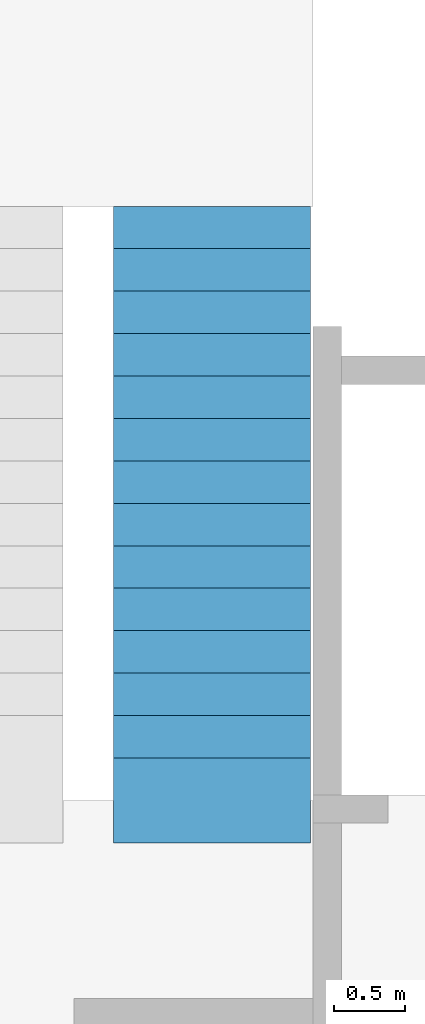
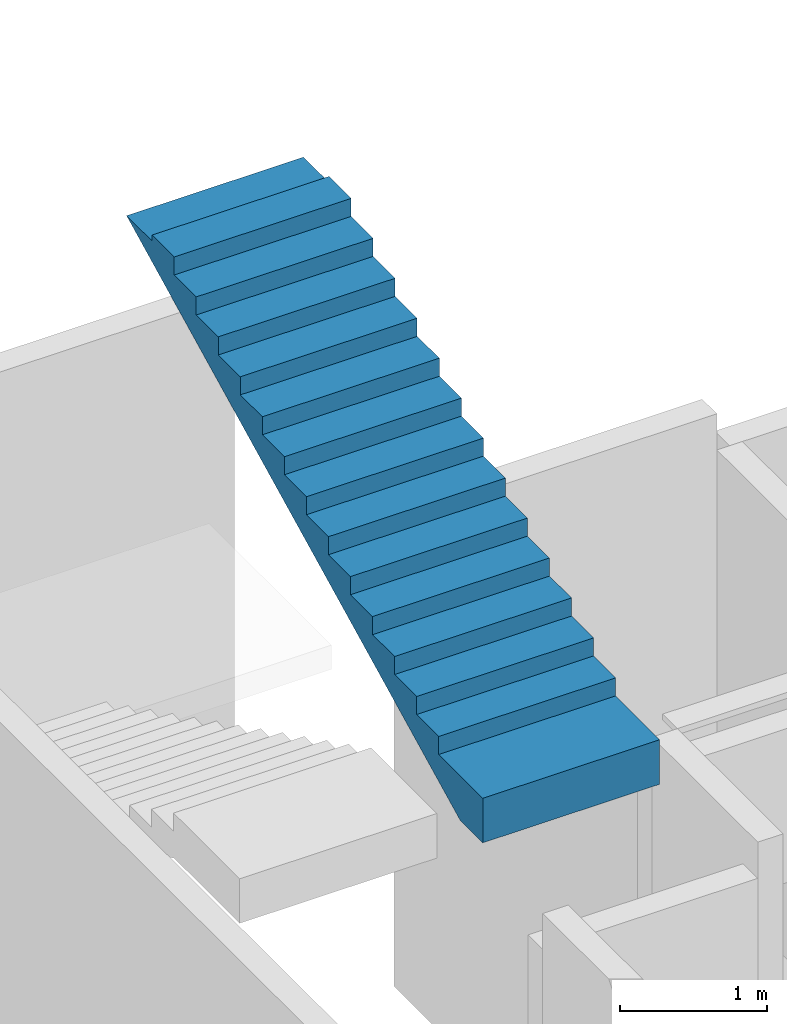
# One storey, part 22 of 92: 1 stair.
"""IFC4 building model written with IfcOpenShell, lengths in millimetres."""

from ifc_helpers import new_model, entity, si_unit, converted_unit, derived_unit, direction, frame, origin, place, context, subcontext, project, spatial, indexed_curve, outline, extrude, material, type_object, element, save


model = new_model("IFC4")

# Units and contexts
model_context = context("Model", 3, precision=0.01, world=origin(), true_north=direction((6.12303176911189e-17, 1.0)))
plan_context = context("Plan", 3, precision=0.01, world=origin(), true_north=direction((6.12303176911189e-17, 1.0)))
body_context = subcontext(model_context, "Body", "Model", "MODEL_VIEW")
ifc_project = project(units=[si_unit("LENGTHUNIT", "METRE", prefix="MILLI"), si_unit("AREAUNIT", "SQUARE_METRE"), si_unit("VOLUMEUNIT", "CUBIC_METRE"), converted_unit("PLANEANGLEUNIT", "DEGREE", entity("IfcRatioMeasure", 0.0174532925199433), si_unit("PLANEANGLEUNIT", "RADIAN"), dimensions=[0, 0, 0, 0, 0, 0, 0]), si_unit("MASSUNIT", "GRAM", prefix="KILO"), derived_unit("MASSDENSITYUNIT", [(si_unit("MASSUNIT", "GRAM", prefix="KILO"), 1), (si_unit("LENGTHUNIT", "METRE"), -3)]), derived_unit("MOMENTOFINERTIAUNIT", [(si_unit("LENGTHUNIT", "METRE"), 4)]), si_unit("TIMEUNIT", "SECOND"), si_unit("FREQUENCYUNIT", "HERTZ"), si_unit("THERMODYNAMICTEMPERATUREUNIT", "DEGREE_CELSIUS"), derived_unit("THERMALTRANSMITTANCEUNIT", [(si_unit("MASSUNIT", "GRAM", prefix="KILO"), 1), (si_unit("THERMODYNAMICTEMPERATUREUNIT", "KELVIN"), -1), (si_unit("TIMEUNIT", "SECOND"), -3)]), derived_unit("VOLUMETRICFLOWRATEUNIT", [(si_unit("LENGTHUNIT", "METRE"), 3), (si_unit("TIMEUNIT", "SECOND"), -1)]), derived_unit("MASSFLOWRATEUNIT", [(si_unit("MASSUNIT", "GRAM", prefix="KILO"), 1), (si_unit("TIMEUNIT", "SECOND"), -1)]), derived_unit("ROTATIONALFREQUENCYUNIT", [(si_unit("TIMEUNIT", "SECOND"), -1)]), si_unit("ELECTRICCURRENTUNIT", "AMPERE"), si_unit("ELECTRICVOLTAGEUNIT", "VOLT"), si_unit("POWERUNIT", "WATT"), si_unit("FORCEUNIT", "NEWTON", prefix="KILO"), si_unit("ILLUMINANCEUNIT", "LUX"), si_unit("LUMINOUSFLUXUNIT", "LUMEN"), si_unit("LUMINOUSINTENSITYUNIT", "CANDELA"), derived_unit("USERDEFINED", [(si_unit("MASSUNIT", "GRAM", prefix="KILO"), -1), (si_unit("LENGTHUNIT", "METRE"), -2), (si_unit("TIMEUNIT", "SECOND"), 3), (si_unit("LUMINOUSFLUXUNIT", "LUMEN"), 1)]), derived_unit("LINEARVELOCITYUNIT", [(si_unit("LENGTHUNIT", "METRE"), 1), (si_unit("TIMEUNIT", "SECOND"), -1)]), si_unit("PRESSUREUNIT", "PASCAL"), derived_unit("USERDEFINED", [(si_unit("LENGTHUNIT", "METRE"), -2), (si_unit("MASSUNIT", "GRAM", prefix="KILO"), 1), (si_unit("TIMEUNIT", "SECOND"), -2)]), derived_unit("LINEARFORCEUNIT", [(si_unit("MASSUNIT", "GRAM", prefix="KILO"), 1), (si_unit("LENGTHUNIT", "METRE"), 1), (si_unit("TIMEUNIT", "SECOND"), -2), (si_unit("LENGTHUNIT", "METRE"), -1)]), derived_unit("PLANARFORCEUNIT", [(si_unit("MASSUNIT", "GRAM", prefix="KILO"), 1), (si_unit("LENGTHUNIT", "METRE"), 1), (si_unit("TIMEUNIT", "SECOND"), -2), (si_unit("LENGTHUNIT", "METRE"), -2)])], contexts=[model_context, plan_context])

# Site, building, storey
site_placement = place(None, origin())
site = spatial("IfcSite", under=ifc_project, at=site_placement, CompositionType="ELEMENT")
building_placement = place(site_placement, origin())
building = spatial("IfcBuilding", under=site, at=building_placement, CompositionType="ELEMENT")
storey_placement = place(building_placement, frame((0.0, 0.0, 15900.0)))
storey = spatial("IfcBuildingStorey", under=building, at=storey_placement, Name="05", CompositionType="ELEMENT", Elevation=15900.0)

# Stair
ifc_material = material()
stair_type = type_object("IfcStairType", Name="19: 15", PredefinedType="HALF_TURN_STAIR")
stair_placement = place(storey_placement, origin())
element("IfcStair", 1, at=stair_placement, inside=storey, type_object=stair_type, material=ifc_material, Name="19: 15", ObjectType="19: 15", PredefinedType="HALF_TURN_STAIR", context=body_context, shape_type="SweptSolid", body=[
    extrude(outline(indexed_curve([(919.999999999986, -2328.92203609093), (1289.99999999999, -2328.92203609093), (1289.99999999999, -2021.70844059097), (-980.000000000011, 2518.29155940903), (-980.000000000011, 2171.07796390909), (-1030.00000000001, 2171.07796390909), (-1030.00000000001, 1871.07796390909), (-880.000000000016, 1871.07796390909), (-880.000000000016, 1571.07796390909), (-730.000000000016, 1571.07796390909), (-730.000000000016, 1271.07796390908), (-580.000000000015, 1271.07796390908), (-580.000000000015, 971.077963909084), (-430.000000000015, 971.077963909084), (-430.000000000015, 671.077963909082), (-280.000000000014, 671.077963909082), (-280.000000000014, 371.077963909081), (-130.000000000014, 371.077963909081), (-130.000000000014, 71.0779639090803), (19.9999999999868, 71.0779639090803), (19.9999999999868, -228.922036090921), (169.999999999987, -228.922036090921), (169.999999999987, -528.922036090922), (319.999999999988, -528.922036090922), (319.999999999988, -828.922036090923), (469.999999999988, -828.922036090923), (469.999999999988, -1128.92203609092), (619.999999999989, -1128.92203609092), (619.999999999989, -1428.92203609093), (769.999999999985, -1428.92203609093), (769.999999999985, -1728.92203609093), (919.999999999986, -1728.92203609093), (919.999999999986, -2328.92203609093)], self_intersect=False)), frame((67360.0, 16458.92, 4790.0), z_axis=(1.0, 0.0, 0.0), x_axis=(0.0, 0.0, -1.0)), (0.0, 0.0, 1.0), 1390.0),
])

save(model, "model.ifc")
